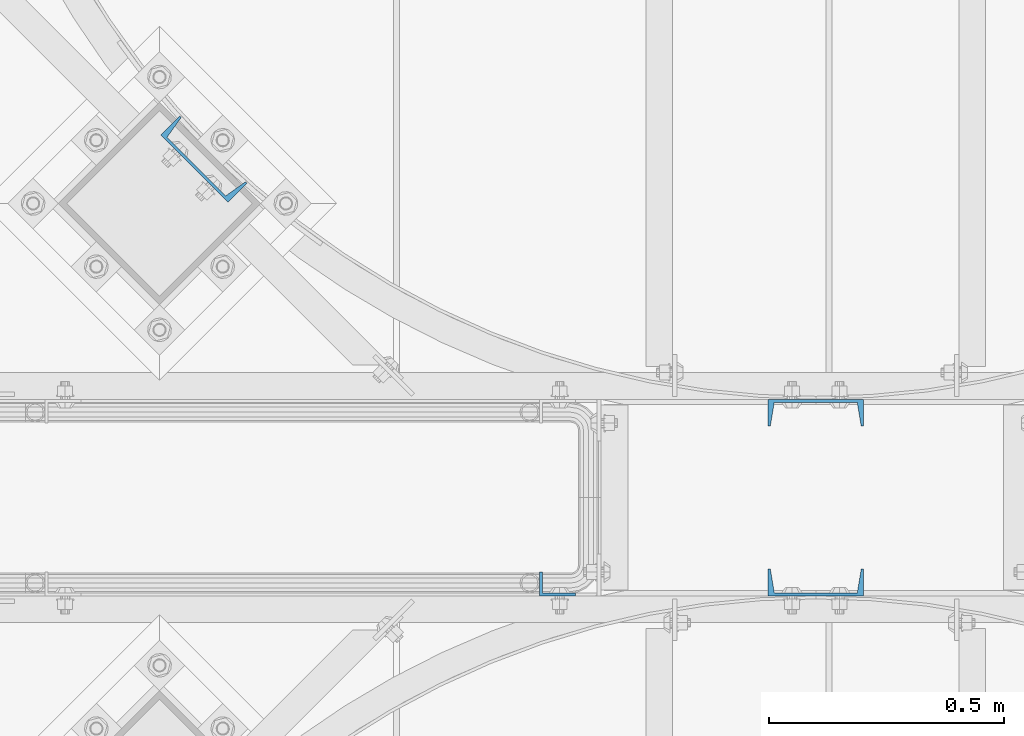
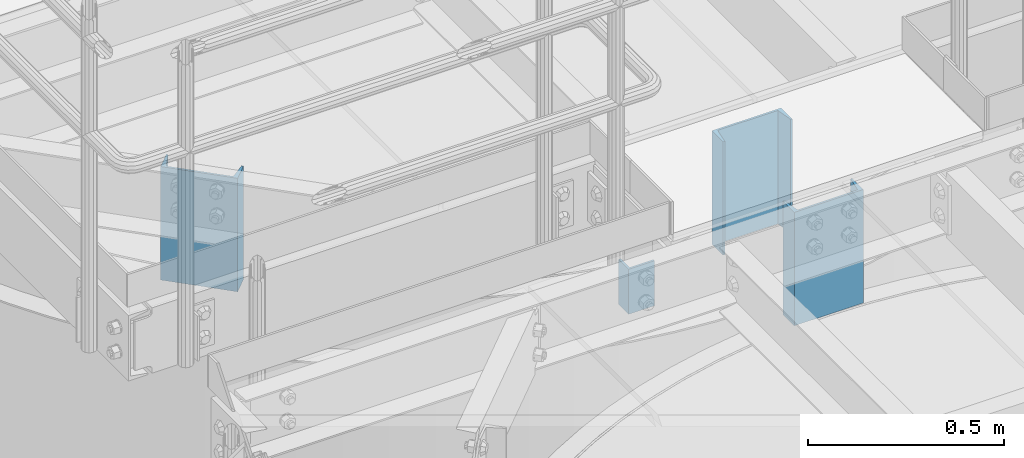
# One storey, part 791 of 1876: 4 columns, 4 elements without a shape of their own.
"""IFC2X3 building model written with IfcOpenShell, lengths in millimetres."""

from ifc_helpers import new_model, si_unit, frame, origin_with_axes, place, context, subcontext, project, spatial, faceted_brep, material, type_object, element, aggregate, save


model = new_model("IFC2X3")

# Units and contexts
model_context = context("Model", 3, precision=1e-05, world=origin_with_axes())
body_context = subcontext(model_context, "Body", "Model", "MODEL_VIEW")
ifc_project = project(units=[si_unit("LENGTHUNIT", "METRE", prefix="MILLI"), si_unit("AREAUNIT", "SQUARE_METRE"), si_unit("VOLUMEUNIT", "CUBIC_METRE"), si_unit("MASSUNIT", "GRAM", prefix="KILO"), si_unit("TIMEUNIT", "SECOND"), si_unit("PLANEANGLEUNIT", "RADIAN"), si_unit("SOLIDANGLEUNIT", "STERADIAN"), si_unit("THERMODYNAMICTEMPERATUREUNIT", "DEGREE_CELSIUS"), si_unit("LUMINOUSINTENSITYUNIT", "LUMEN")], contexts=[model_context])

# Site, building, storey
site_placement = place(None, origin_with_axes())
site = spatial("IfcSite", under=ifc_project, at=site_placement, CompositionType="ELEMENT")
building_placement = place(site_placement, origin_with_axes())
building = spatial("IfcBuilding", under=site, at=building_placement, Name="Undefined", CompositionType="ELEMENT")
storey_placement = place(building_placement, origin_with_axes())
storey = spatial("IfcBuildingStorey", under=building, at=storey_placement, Name="Undefined", CompositionType="ELEMENT", Elevation=0.0)

# Assembly, column
assembly_1_placement = place(storey_placement, origin_with_axes())
assembly_1 = element("IfcElementAssembly", 1, at=assembly_1_placement, inside=storey, Name="HANDRAIL", AssemblyPlace="NOTDEFINED", PredefinedType="RIGID_FRAME")
ifc_material = material(Name="STEEL/A36")
column_type_1 = type_object("IfcColumnType", Name="L3X2X1/4", PredefinedType="NOTDEFINED")
column_1_placement = place(assembly_1_placement, frame((4631.18343150122, -11747.4644531238, 7826.375), z_axis=(1.0, 0.0, 0.0), x_axis=(0.0, 0.0, 1.0)))
column_1 = element("IfcColumn", 2, at=column_1_placement, type_object=column_type_1, material=ifc_material, Name="ANGLE", ObjectType="L3X2X1/4", context=body_context, shape_type="Brep", body=[
    faceted_brep([(0.0, 25.3999999999996, -38.1000000000004), (0.0, 25.3999999999996, 38.1000000000004), (139.7, 25.3999999999996, 38.1000000000004), (139.7, 25.3999999999996, -38.1000000000004), (0.0, 19.0500000000002, 38.1000000000004), (139.7, 19.0500000000002, 38.1000000000004), (0.0, 19.0500000000002, -31.75), (139.7, 19.0500000000002, -31.75), (0.0, -25.3999999999996, -31.75), (139.7, -25.3999999999996, -31.75), (0.0, -25.3999999999996, -38.1000000000004), (139.7, -25.3999999999996, -38.1000000000004)], [[[0, 1, 2, 3]], [[1, 4, 5, 2]], [[4, 6, 7, 5]], [[6, 8, 9, 7]], [[8, 10, 11, 9]], [[10, 0, 3, 11]], [[5, 7, 9, 11, 3, 2]], [[10, 8, 6, 4, 1, 0]]]),
])
aggregate(assembly_1, [column_1])

assembly_2_placement = place(storey_placement, origin_with_axes())
assembly_2 = element("IfcElementAssembly", 3, at=assembly_2_placement, inside=storey, Name="BEAM", AssemblyPlace="NOTDEFINED", PredefinedType="RIGID_FRAME")
column_type_2 = type_object("IfcColumnType", Name="C8X11.5", PredefinedType="NOTDEFINED")
column_2_placement = place(assembly_2_placement, frame((5181.60331443577, -11382.4104980488, 7620.0), z_axis=(-1.0, 0.0, 0.0), x_axis=(0.0, 0.0, 1.0)))
column_2 = element("IfcColumn", 4, at=column_2_placement, type_object=column_type_2, material=ifc_material, Name="BEAM", ObjectType="C8X11.5", context=body_context, shape_type="Brep", body=[
    faceted_brep([(0.0, 28.5749999999998, -101.6), (0.0, 28.5749999999998, 101.6), (352.425, 28.5749999999998, 101.6), (352.425, 28.5749999999998, -101.6), (0.0, -28.5749999999998, 101.6), (352.425, -28.5749999999998, 101.6), (0.0, -28.5749999999998, 96.8355950000005), (352.425, -28.5749999999998, 96.8355950000005), (0.0, 22.2250000000004, 88.3723150000005), (352.425, 22.2250000000004, 88.3723150000005), (0.0, 22.2250000000004, -88.3723150000005), (352.425, 22.2250000000004, -88.3723150000005), (0.0, -28.5749999999998, -96.8355950000005), (352.425, -28.5749999999998, -96.8355950000005), (0.0, -28.5749999999998, -101.6), (352.425, -28.5749999999998, -101.6)], [[[0, 1, 2, 3]], [[1, 4, 5, 2]], [[4, 6, 7, 5]], [[6, 8, 9, 7]], [[8, 10, 11, 9]], [[10, 12, 13, 11]], [[12, 14, 15, 13]], [[14, 0, 3, 15]], [[5, 7, 9, 11, 13, 15, 3, 2]], [[14, 12, 10, 8, 6, 4, 1, 0]]]),
])
aggregate(assembly_2, [column_2])

assembly_3_placement = place(storey_placement, origin_with_axes())
assembly_3 = element("IfcElementAssembly", 5, at=assembly_3_placement, inside=storey, Name="BEAM", AssemblyPlace="NOTDEFINED", PredefinedType="RIGID_FRAME")
column_3_placement = place(assembly_3_placement, frame((3877.23860212227, -10842.0290921963, 7620.01566278096), z_axis=(0.707106781186547, -0.707106781186548, 0.0), x_axis=(0.0, 0.0, 1.0)))
column_3 = element("IfcColumn", 6, at=column_3_placement, type_object=column_type_2, material=ifc_material, Name="BEAM", ObjectType="C8X11.5", context=body_context, shape_type="Brep", body=[
    faceted_brep([(0.0, 28.5749999999998, -101.6), (0.0, 28.5749999999998, 101.6), (352.425, 28.5749999999998, 101.6), (352.425, 28.5749999999998, -101.6), (0.0, -28.5749999999998, 101.6), (352.425, -28.5749999999998, 101.6), (0.0, -28.5749999999998, 96.8355950000005), (352.425, -28.5749999999998, 96.8355950000005), (0.0, 22.2250000000004, 88.3723150000005), (352.425, 22.2250000000004, 88.3723150000005), (0.0, 22.2250000000004, -88.3723150000005), (352.425, 22.2250000000004, -88.3723150000005), (0.0, -28.5749999999998, -96.8355950000005), (352.425, -28.5749999999998, -96.8355950000005), (0.0, -28.5749999999998, -101.6), (352.425, -28.5749999999998, -101.6)], [[[0, 1, 2, 3]], [[1, 4, 5, 2]], [[4, 6, 7, 5]], [[6, 8, 9, 7]], [[8, 10, 11, 9]], [[10, 12, 13, 11]], [[12, 14, 15, 13]], [[14, 0, 3, 15]], [[5, 7, 9, 11, 13, 15, 3, 2]], [[14, 12, 10, 8, 6, 4, 1, 0]]]),
])
aggregate(assembly_3, [column_3])

assembly_4_placement = place(storey_placement, origin_with_axes())
assembly_4 = element("IfcElementAssembly", 7, at=assembly_4_placement, inside=storey, Name="BEAM", AssemblyPlace="NOTDEFINED", PredefinedType="RIGID_FRAME")
column_4_placement = place(assembly_4_placement, frame((5181.60140708777, -11744.2894531231, 7620.01566278096), z_axis=(1.0, 0.0, 0.0), x_axis=(0.0, 0.0, 1.0)))
column_4 = element("IfcColumn", 8, at=column_4_placement, type_object=column_type_2, material=ifc_material, Name="BEAM", ObjectType="C8X11.5", context=body_context, shape_type="Brep", body=[
    faceted_brep([(0.0, 28.5749999999998, -101.6), (0.0, 28.5749999999998, 101.6), (352.425, 28.5749999999998, 101.6), (352.425, 28.5749999999998, -101.6), (0.0, -28.5749999999998, 101.6), (352.425, -28.5749999999998, 101.6), (0.0, -28.5749999999998, 96.8355950000005), (352.425, -28.5749999999998, 96.8355950000005), (0.0, 22.2250000000004, 88.3723150000005), (352.425, 22.2250000000004, 88.3723150000005), (0.0, 22.2250000000004, -88.3723150000005), (352.425, 22.2250000000004, -88.3723150000005), (0.0, -28.5749999999998, -96.8355950000005), (352.425, -28.5749999999998, -96.8355950000005), (0.0, -28.5749999999998, -101.6), (352.425, -28.5749999999998, -101.6)], [[[0, 1, 2, 3]], [[1, 4, 5, 2]], [[4, 6, 7, 5]], [[6, 8, 9, 7]], [[8, 10, 11, 9]], [[10, 12, 13, 11]], [[12, 14, 15, 13]], [[14, 0, 3, 15]], [[5, 7, 9, 11, 13, 15, 3, 2]], [[14, 12, 10, 8, 6, 4, 1, 0]]]),
])
aggregate(assembly_4, [column_4])

save(model, "model.ifc")
